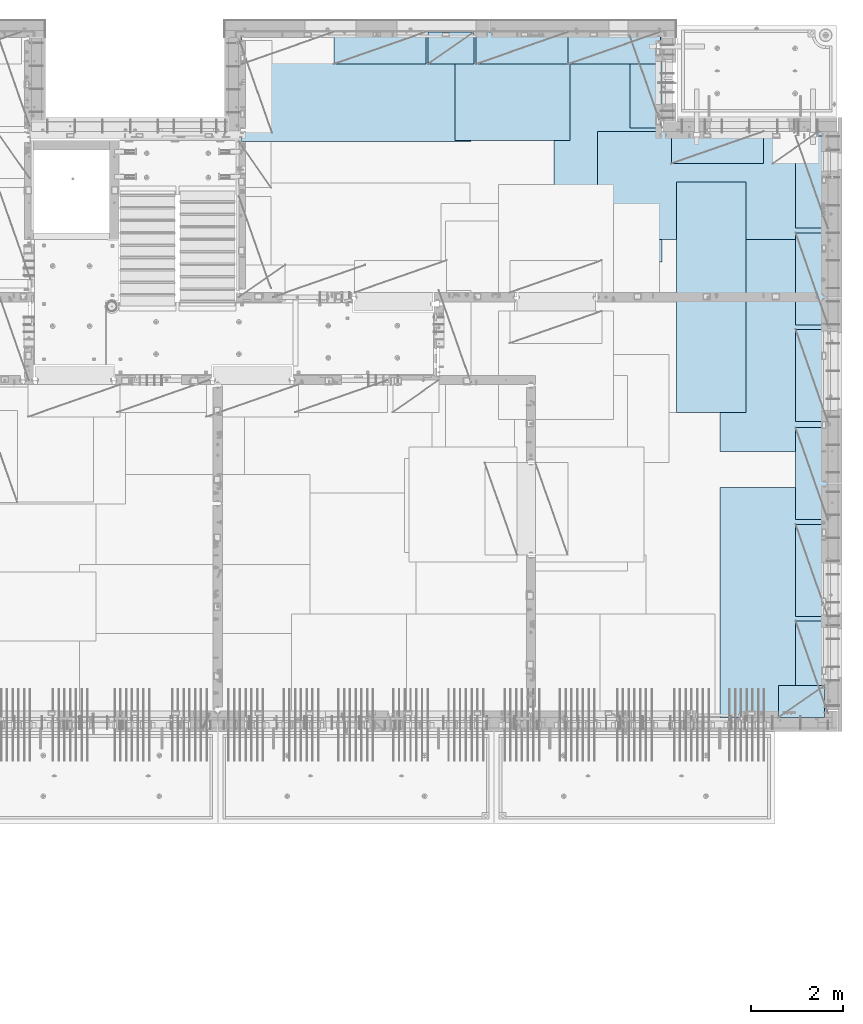
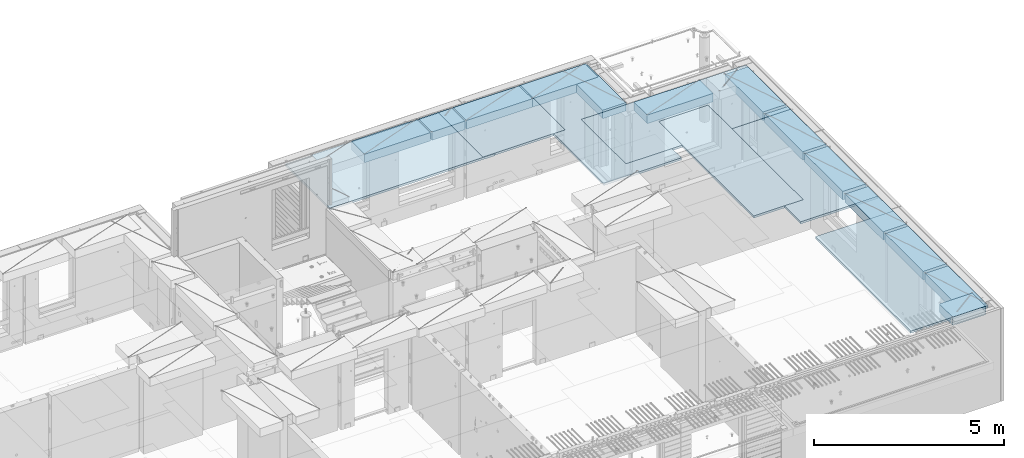
# One storey, part 210 of 349: 20 plates, 20 elements without a shape of their own.
"""IFC2X3 building model written with IfcOpenShell, lengths in millimetres."""

from ifc_helpers import new_model, si_unit, frame, origin_with_axes, place, context, subcontext, project, spatial, faceted_brep, material, type_object, element, aggregate, save


model = new_model("IFC2X3")

# Units and contexts
model_context = context("Model", 3, precision=1e-05, world=origin_with_axes())
body_context = subcontext(model_context, "Body", "Model", "MODEL_VIEW")
ifc_project = project(units=[si_unit("LENGTHUNIT", "METRE", prefix="MILLI"), si_unit("AREAUNIT", "SQUARE_METRE"), si_unit("VOLUMEUNIT", "CUBIC_METRE"), si_unit("MASSUNIT", "GRAM", prefix="KILO"), si_unit("TIMEUNIT", "SECOND"), si_unit("PLANEANGLEUNIT", "RADIAN"), si_unit("SOLIDANGLEUNIT", "STERADIAN"), si_unit("THERMODYNAMICTEMPERATUREUNIT", "DEGREE_CELSIUS"), si_unit("LUMINOUSINTENSITYUNIT", "LUMEN")], contexts=[model_context])

# Site, building, storey
site_placement = place(None, origin_with_axes())
site = spatial("IfcSite", under=ifc_project, at=site_placement, CompositionType="ELEMENT")
building_placement = place(site_placement, origin_with_axes())
building = spatial("IfcBuilding", under=site, at=building_placement, CompositionType="ELEMENT")
storey_placement = place(building_placement, origin_with_axes())
storey = spatial("IfcBuildingStorey", under=building, at=storey_placement, Name="4", CompositionType="ELEMENT", Elevation=0.0)

# Assembly, plate
assembly_1_placement = place(storey_placement, origin_with_axes())
assembly_1 = element("IfcElementAssembly", 1, at=assembly_1_placement, inside=storey, Name="Steel Assembly", AssemblyPlace="NOTDEFINED", PredefinedType="NOTDEFINED")
ifc_material = material()
plate_type_1 = type_object("IfcPlateType", PredefinedType="NOTDEFINED")
plate_1_placement = place(assembly_1_placement, frame((26960.07, 22728.45, 93695.1), z_axis=(1.0, 0.0, 0.0), x_axis=(0.0, -1.0, 0.0)))
plate_1 = element("IfcPlate", 2, at=plate_1_placement, type_object=plate_type_1, material=ifc_material, Name="1/2", context=body_context, shape_type="Brep", body=[
    faceted_brep([(0.0, -35.0, 0.0), (0.0, -35.0, 2500.0), (0.0, 35.0, 2500.0), (0.0, 35.0, 0.0), (2349.99951171875, -35.0, 2500.0), (2349.99951171875, 35.0, 2500.0), (2350.0, -35.0, 0.0), (2350.0, 35.0, 0.0)], [[[0, 1, 2, 3]], [[1, 4, 5, 2]], [[4, 6, 7, 5]], [[6, 0, 3, 7]], [[5, 7, 3, 2]], [[6, 4, 1, 0]]]),
])
aggregate(assembly_1, [plate_1])

assembly_2_placement = place(storey_placement, origin_with_axes())
assembly_2 = element("IfcElementAssembly", 3, at=assembly_2_placement, inside=storey, Name="Steel Assembly", AssemblyPlace="NOTDEFINED", PredefinedType="NOTDEFINED")
plate_2_placement = place(assembly_2_placement, frame((22309.9998779297, 22710.0009765625, 93695.1), z_axis=(1.0, 0.0, 0.0), x_axis=(0.0, -1.0, 0.0)))
plate_2 = element("IfcPlate", 4, at=plate_2_placement, type_object=plate_type_1, material=ifc_material, context=body_context, shape_type="Brep", body=[
    faceted_brep([(0.0, -35.0, 0.0), (0.0, -35.0, 5000.0), (0.0, 35.0, 5000.0), (0.0, 35.0, 0.0), (2349.99951171875, -35.0, 5000.0), (2349.99951171875, 35.0, 5000.0), (2350.0, -35.0, 0.0), (2350.0, 35.0, 0.0)], [[[0, 1, 2, 3]], [[1, 4, 5, 2]], [[4, 6, 7, 5]], [[6, 0, 3, 7]], [[5, 7, 3, 2]], [[6, 4, 1, 0]]]),
])
aggregate(assembly_2, [plate_2])

assembly_3_placement = place(storey_placement, origin_with_axes())
assembly_3 = element("IfcElementAssembly", 5, at=assembly_3_placement, inside=storey, Name="Steel Assembly", AssemblyPlace="NOTDEFINED", PredefinedType="NOTDEFINED")
plate_3_placement = place(assembly_3_placement, frame((31460.0, 22740.0, 93695.1), z_axis=(0.0, -1.0, 0.0), x_axis=(-1.0, 3.00000001838171e-08, 0.0)))
plate_3 = element("IfcPlate", 6, at=plate_3_placement, type_object=plate_type_1, material=ifc_material, context=body_context, shape_type="Brep", body=[
    faceted_brep([(0.0, -35.0, 0.0), (0.0, -35.0, 5000.0), (0.0, 35.0, 5000.0), (0.0, 35.0, 0.0), (2349.99951171875, -35.0, 5000.0), (2349.99951171875, 35.0, 5000.0), (2350.0, -35.0, 0.0), (2350.0, 35.0, 0.0)], [[[0, 1, 2, 3]], [[1, 4, 5, 2]], [[4, 6, 7, 5]], [[6, 0, 3, 7]], [[5, 7, 3, 2]], [[6, 4, 1, 0]]]),
])
aggregate(assembly_3, [plate_3])

assembly_4_placement = place(storey_placement, origin_with_axes())
assembly_4 = element("IfcElementAssembly", 7, at=assembly_4_placement, inside=storey, Name="Steel Assembly", AssemblyPlace="NOTDEFINED", PredefinedType="NOTDEFINED")
plate_4_placement = place(assembly_4_placement, frame((35060.0, 12850.0, 93695.1), z_axis=(0.0, -1.0, 0.0), x_axis=(-1.0, 3.00000001838171e-08, 0.0)))
plate_4 = element("IfcPlate", 8, at=plate_4_placement, type_object=plate_type_1, material=ifc_material, context=body_context, shape_type="Brep", body=[
    faceted_brep([(0.0, -35.0, 0.0), (0.0, -35.0, 5000.0), (0.0, 35.0, 5000.0), (0.0, 35.0, 0.0), (2349.99951171875, -35.0, 5000.0), (2349.99951171875, 35.0, 5000.0), (2350.0, -35.0, 0.0), (2350.0, 35.0, 0.0)], [[[0, 1, 2, 3]], [[1, 4, 5, 2]], [[4, 6, 7, 5]], [[6, 0, 3, 7]], [[5, 7, 3, 2]], [[6, 4, 1, 0]]]),
])
aggregate(assembly_4, [plate_4])

assembly_5_placement = place(storey_placement, origin_with_axes())
assembly_5 = element("IfcElementAssembly", 9, at=assembly_5_placement, inside=storey, Name="Steel Assembly", AssemblyPlace="NOTDEFINED", PredefinedType="NOTDEFINED")
plate_5_placement = place(assembly_5_placement, frame((35060.0, 18630.0, 93695.1), z_axis=(0.0, -1.0, 0.0), x_axis=(-1.0, 3.00000001838171e-08, 0.0)))
plate_5 = element("IfcPlate", 10, at=plate_5_placement, type_object=plate_type_1, material=ifc_material, context=body_context, shape_type="Brep", body=[
    faceted_brep([(0.0, -35.0, 0.0), (0.0, -35.0, 5000.0), (0.0, 35.0, 5000.0), (0.0, 35.0, 0.0), (2349.99951171875, -35.0, 5000.0), (2349.99951171875, 35.0, 5000.0), (2350.0, -35.0, 0.0), (2350.0, 35.0, 0.0)], [[[0, 1, 2, 3]], [[1, 4, 5, 2]], [[4, 6, 7, 5]], [[6, 0, 3, 7]], [[5, 7, 3, 2]], [[6, 4, 1, 0]]]),
])
aggregate(assembly_5, [plate_5])

assembly_6_placement = place(storey_placement, origin_with_axes())
assembly_6 = element("IfcElementAssembly", 11, at=assembly_6_placement, inside=storey, Name="Steel Assembly", AssemblyPlace="NOTDEFINED", PredefinedType="NOTDEFINED")
plate_6_placement = place(assembly_6_placement, frame((30060.0, 20580.0, 93695.1), z_axis=(1.0, 0.0, 0.0), x_axis=(0.0, -1.0, 0.0)))
plate_6 = element("IfcPlate", 12, at=plate_6_placement, type_object=plate_type_1, material=ifc_material, context=body_context, shape_type="Brep", body=[
    faceted_brep([(0.0, -35.0, 0.0), (0.0, -35.0, 5000.0), (0.0, 35.0, 5000.0), (0.0, 35.0, 0.0), (2349.99951171875, -35.0, 5000.0), (2349.99951171875, 35.0, 5000.0), (2350.0, -35.0, 0.0), (2350.0, 35.0, 0.0)], [[[0, 1, 2, 3]], [[1, 4, 5, 2]], [[4, 6, 7, 5]], [[6, 0, 3, 7]], [[5, 7, 3, 2]], [[6, 4, 1, 0]]]),
])
aggregate(assembly_6, [plate_6])

assembly_7_placement = place(storey_placement, origin_with_axes())
assembly_7 = element("IfcElementAssembly", 13, at=assembly_7_placement, inside=storey, Name="Steel Assembly", AssemblyPlace="NOTDEFINED", PredefinedType="NOTDEFINED")
plate_type_2 = type_object("IfcPlateType", PredefinedType="NOTDEFINED")
plate_7_placement = place(assembly_7_placement, frame((33275.0000122641, 19480.0, 93695.1000003815), z_axis=(0.0, -1.0, 0.0), x_axis=(-1.0, 3.00000001838171e-08, 0.0)))
plate_7 = element("IfcPlate", 14, at=plate_7_placement, type_object=plate_type_2, material=ifc_material, context=body_context, shape_type="Brep", body=[
    faceted_brep([(0.0, -35.0, 0.0), (0.0, -35.0, 5000.0), (0.0, 35.0, 5000.0), (0.0, 35.0, 0.0), (1499.99951171875, -35.0, 5000.0), (1499.99951171875, 35.0, 5000.0), (1500.0, -35.0, 0.0), (1500.0, 35.0, 0.0)], [[[0, 1, 2, 3]], [[1, 4, 5, 2]], [[4, 6, 7, 5]], [[6, 0, 3, 7]], [[5, 7, 3, 2]], [[6, 4, 1, 0]]]),
])
aggregate(assembly_7, [plate_7])

assembly_8_placement = place(storey_placement, origin_with_axes())
assembly_8 = element("IfcElementAssembly", 15, at=assembly_8_placement, inside=storey, Name="Steel Assembly", AssemblyPlace="NOTDEFINED", PredefinedType="NOTDEFINED")
plate_type_3 = type_object("IfcPlateType", PredefinedType="NOTDEFINED")
plate_8_placement = place(assembly_8_placement, frame((31420.0, 22740.0001220703, 93595.3), z_axis=(0.0, -1.0, 0.0), x_axis=(-1.0, 3.00000001838171e-08, 0.0)))
plate_8 = element("IfcPlate", 16, at=plate_8_placement, type_object=plate_type_3, material=ifc_material, Name="RE1", context=body_context, shape_type="Brep", body=[
    faceted_brep([(1.81898940354586e-12, -135.0, 1.81898940354586e-12), (0.0, -135.0, 699.999999999996), (0.0, 135.0, 699.999999999996), (1.81898940354586e-12, 135.0, 1.81898940354586e-12), (1999.99951171875, -135.0, 699.999999999993), (1999.99951171875, 135.0, 699.999999999993), (2000.0, -135.0, -3.63797880709171e-12), (2000.0, 135.0, -3.63797880709171e-12)], [[[0, 1, 2, 3]], [[1, 4, 5, 2]], [[4, 6, 7, 5]], [[6, 0, 3, 7]], [[5, 7, 3, 2]], [[6, 4, 1, 0]]]),
])
aggregate(assembly_8, [plate_8])

assembly_9_placement = place(storey_placement, origin_with_axes())
assembly_9 = element("IfcElementAssembly", 17, at=assembly_9_placement, inside=storey, Name="Steel Assembly", AssemblyPlace="NOTDEFINED", PredefinedType="NOTDEFINED")
plate_9_placement = place(assembly_9_placement, frame((33985.0, 7849.99999992931, 93595.3), z_axis=(0.0, 1.0, 0.0), x_axis=(1.0, 0.0, 0.0)))
plate_9 = element("IfcPlate", 18, at=plate_9_placement, type_object=plate_type_3, material=ifc_material, Name="RE1_1/2", context=body_context, shape_type="Brep", body=[
    faceted_brep([(1.81898940354586e-12, -135.0, 1.81898940354586e-12), (0.0, -135.0, 699.999999999996), (0.0, 135.0, 699.999999999996), (1.81898940354586e-12, 135.0, 1.81898940354586e-12), (999.99951171875, -135.0, 700.0), (999.99951171875, 135.0, 700.0), (1000.0, -135.0, 0.0), (1000.0, 135.0, 0.0)], [[[0, 1, 2, 3]], [[1, 4, 5, 2]], [[4, 6, 7, 5]], [[6, 0, 3, 7]], [[5, 7, 3, 2]], [[6, 4, 1, 0]]]),
])
aggregate(assembly_9, [plate_9])

assembly_10_placement = place(storey_placement, origin_with_axes())
assembly_10 = element("IfcElementAssembly", 19, at=assembly_10_placement, inside=storey, Name="Steel Assembly", AssemblyPlace="NOTDEFINED", PredefinedType="NOTDEFINED")
plate_10_placement = place(assembly_10_placement, frame((35060.0001220703, 14280.0, 93595.3), z_axis=(-1.0, 3.00000001838171e-08, 0.0), x_axis=(0.0, 1.0, 0.0)))
plate_10 = element("IfcPlate", 20, at=plate_10_placement, type_object=plate_type_3, material=ifc_material, Name="RE1", context=body_context, shape_type="Brep", body=[
    faceted_brep([(1.81898940354586e-12, -135.0, 1.81898940354586e-12), (0.0, -135.0, 699.999999999996), (0.0, 135.0, 699.999999999996), (1.81898940354586e-12, 135.0, 1.81898940354586e-12), (1999.99951171875, -135.0, 699.999999999993), (1999.99951171875, 135.0, 699.999999999993), (2000.0, -135.0, -3.63797880709171e-12), (2000.0, 135.0, -3.63797880709171e-12)], [[[0, 1, 2, 3]], [[1, 4, 5, 2]], [[4, 6, 7, 5]], [[6, 0, 3, 7]], [[5, 7, 3, 2]], [[6, 4, 1, 0]]]),
])
aggregate(assembly_10, [plate_10])

assembly_11_placement = place(storey_placement, origin_with_axes())
assembly_11 = element("IfcElementAssembly", 21, at=assembly_11_placement, inside=storey, Name="Steel Assembly", AssemblyPlace="NOTDEFINED", PredefinedType="NOTDEFINED")
plate_11_placement = place(assembly_11_placement, frame((35060.0001220703, 16380.0, 93595.3), z_axis=(-1.0, 3.00000001838171e-08, 0.0), x_axis=(0.0, 1.0, 0.0)))
plate_11 = element("IfcPlate", 22, at=plate_11_placement, type_object=plate_type_3, material=ifc_material, Name="RE1", context=body_context, shape_type="Brep", body=[
    faceted_brep([(1.81898940354586e-12, -135.0, 1.81898940354586e-12), (0.0, -135.0, 699.999999999996), (0.0, 135.0, 699.999999999996), (1.81898940354586e-12, 135.0, 1.81898940354586e-12), (1999.99951171875, -135.0, 699.999999999993), (1999.99951171875, 135.0, 699.999999999993), (2000.0, -135.0, -3.63797880709171e-12), (2000.0, 135.0, -3.63797880709171e-12)], [[[0, 1, 2, 3]], [[1, 4, 5, 2]], [[4, 6, 7, 5]], [[6, 0, 3, 7]], [[5, 7, 3, 2]], [[6, 4, 1, 0]]]),
])
aggregate(assembly_11, [plate_11])

assembly_12_placement = place(storey_placement, origin_with_axes())
assembly_12 = element("IfcElementAssembly", 23, at=assembly_12_placement, inside=storey, Name="Steel Assembly", AssemblyPlace="NOTDEFINED", PredefinedType="NOTDEFINED")
plate_12_placement = place(assembly_12_placement, frame((35060.0001220703, 18480.0, 93595.3), z_axis=(-1.0, 3.00000001838171e-08, 0.0), x_axis=(0.0, 1.0, 0.0)))
plate_12 = element("IfcPlate", 24, at=plate_12_placement, type_object=plate_type_3, material=ifc_material, Name="RE1", context=body_context, shape_type="Brep", body=[
    faceted_brep([(1.81898940354586e-12, -135.0, 1.81898940354586e-12), (0.0, -135.0, 699.999999999996), (0.0, 135.0, 699.999999999996), (1.81898940354586e-12, 135.0, 1.81898940354586e-12), (1999.99951171875, -135.0, 699.999999999993), (1999.99951171875, 135.0, 699.999999999993), (2000.0, -135.0, -3.63797880709171e-12), (2000.0, 135.0, -3.63797880709171e-12)], [[[0, 1, 2, 3]], [[1, 4, 5, 2]], [[4, 6, 7, 5]], [[6, 0, 3, 7]], [[5, 7, 3, 2]], [[6, 4, 1, 0]]]),
])
aggregate(assembly_12, [plate_12])

assembly_13_placement = place(storey_placement, origin_with_axes())
assembly_13 = element("IfcElementAssembly", 25, at=assembly_13_placement, inside=storey, Name="Steel Assembly", AssemblyPlace="NOTDEFINED", PredefinedType="NOTDEFINED")
plate_13_placement = place(assembly_13_placement, frame((35060.0001220703, 12150.0, 93595.3), z_axis=(-1.0, 3.00000001838171e-08, 0.0), x_axis=(0.0, 1.0, 0.0)))
plate_13 = element("IfcPlate", 26, at=plate_13_placement, type_object=plate_type_3, material=ifc_material, Name="RE1", context=body_context, shape_type="Brep", body=[
    faceted_brep([(1.81898940354586e-12, -135.0, 1.81898940354586e-12), (0.0, -135.0, 699.999999999996), (0.0, 135.0, 699.999999999996), (1.81898940354586e-12, 135.0, 1.81898940354586e-12), (1999.99951171875, -135.0, 699.999999999993), (1999.99951171875, 135.0, 699.999999999993), (2000.0, -135.0, -3.63797880709171e-12), (2000.0, 135.0, -3.63797880709171e-12)], [[[0, 1, 2, 3]], [[1, 4, 5, 2]], [[4, 6, 7, 5]], [[6, 0, 3, 7]], [[5, 7, 3, 2]], [[6, 4, 1, 0]]]),
])
aggregate(assembly_13, [plate_13])

assembly_14_placement = place(storey_placement, origin_with_axes())
assembly_14 = element("IfcElementAssembly", 27, at=assembly_14_placement, inside=storey, Name="Steel Assembly", AssemblyPlace="NOTDEFINED", PredefinedType="NOTDEFINED")
plate_14_placement = place(assembly_14_placement, frame((35060.0001220703, 10050.0, 93595.3), z_axis=(-1.0, 3.00000001838171e-08, 0.0), x_axis=(0.0, 1.0, 0.0)))
plate_14 = element("IfcPlate", 28, at=plate_14_placement, type_object=plate_type_3, material=ifc_material, Name="RE1", context=body_context, shape_type="Brep", body=[
    faceted_brep([(1.81898940354586e-12, -135.0, 1.81898940354586e-12), (0.0, -135.0, 699.999999999996), (0.0, 135.0, 699.999999999996), (1.81898940354586e-12, 135.0, 1.81898940354586e-12), (1999.99951171875, -135.0, 699.999999999993), (1999.99951171875, 135.0, 699.999999999993), (2000.0, -135.0, -3.63797880709171e-12), (2000.0, 135.0, -3.63797880709171e-12)], [[[0, 1, 2, 3]], [[1, 4, 5, 2]], [[4, 6, 7, 5]], [[6, 0, 3, 7]], [[5, 7, 3, 2]], [[6, 4, 1, 0]]]),
])
aggregate(assembly_14, [plate_14])

assembly_15_placement = place(storey_placement, origin_with_axes())
assembly_15 = element("IfcElementAssembly", 29, at=assembly_15_placement, inside=storey, Name="Steel Assembly", AssemblyPlace="NOTDEFINED", PredefinedType="NOTDEFINED")
plate_15_placement = place(assembly_15_placement, frame((35060.0001220703, 7950.0, 93595.3), z_axis=(-1.0, 3.00000001838171e-08, 0.0), x_axis=(0.0, 1.0, 0.0)))
plate_15 = element("IfcPlate", 30, at=plate_15_placement, type_object=plate_type_3, material=ifc_material, Name="RE1", context=body_context, shape_type="Brep", body=[
    faceted_brep([(1.81898940354586e-12, -135.0, 1.81898940354586e-12), (0.0, -135.0, 699.999999999996), (0.0, 135.0, 699.999999999996), (1.81898940354586e-12, 135.0, 1.81898940354586e-12), (1999.99951171875, -135.0, 699.999999999993), (1999.99951171875, 135.0, 699.999999999993), (2000.0, -135.0, -3.63797880709171e-12), (2000.0, 135.0, -3.63797880709171e-12)], [[[0, 1, 2, 3]], [[1, 4, 5, 2]], [[4, 6, 7, 5]], [[6, 0, 3, 7]], [[5, 7, 3, 2]], [[6, 4, 1, 0]]]),
])
aggregate(assembly_15, [plate_15])

assembly_16_placement = place(storey_placement, origin_with_axes())
assembly_16 = element("IfcElementAssembly", 31, at=assembly_16_placement, inside=storey, Name="Steel Assembly", AssemblyPlace="NOTDEFINED", PredefinedType="NOTDEFINED")
plate_16_placement = place(assembly_16_placement, frame((33660.0, 20580.0001220703, 93595.3), z_axis=(0.0, -1.0, 0.0), x_axis=(-1.0, 3.00000001838171e-08, 0.0)))
plate_16 = element("IfcPlate", 32, at=plate_16_placement, type_object=plate_type_3, material=ifc_material, Name="RE1", context=body_context, shape_type="Brep", body=[
    faceted_brep([(1.81898940354586e-12, -135.0, 1.81898940354586e-12), (0.0, -135.0, 699.999999999996), (0.0, 135.0, 699.999999999996), (1.81898940354586e-12, 135.0, 1.81898940354586e-12), (1999.99951171875, -135.0, 699.999999999993), (1999.99951171875, 135.0, 699.999999999993), (2000.0, -135.0, -3.63797880709171e-12), (2000.0, 135.0, -3.63797880709171e-12)], [[[0, 1, 2, 3]], [[1, 4, 5, 2]], [[4, 6, 7, 5]], [[6, 0, 3, 7]], [[5, 7, 3, 2]], [[6, 4, 1, 0]]]),
])
aggregate(assembly_16, [plate_16])

assembly_17_placement = place(storey_placement, origin_with_axes())
assembly_17 = element("IfcElementAssembly", 33, at=assembly_17_placement, inside=storey, Name="Steel Assembly", AssemblyPlace="NOTDEFINED", PredefinedType="NOTDEFINED")
plate_17_placement = place(assembly_17_placement, frame((31460.0001220703, 20660.0, 93595.3), z_axis=(-1.0, 3.00000001838171e-08, 0.0), x_axis=(0.0, 1.0, 0.0)))
plate_17 = element("IfcPlate", 34, at=plate_17_placement, type_object=plate_type_3, material=ifc_material, Name="RE1", context=body_context, shape_type="Brep", body=[
    faceted_brep([(1.81898940354586e-12, -135.0, 1.81898940354586e-12), (0.0, -135.0, 699.999999999996), (0.0, 135.0, 699.999999999996), (1.81898940354586e-12, 135.0, 1.81898940354586e-12), (1999.99951171875, -135.0, 699.999999999993), (1999.99951171875, 135.0, 699.999999999993), (2000.0, -135.0, -3.63797880709171e-12), (2000.0, 135.0, -3.63797880709171e-12)], [[[0, 1, 2, 3]], [[1, 4, 5, 2]], [[4, 6, 7, 5]], [[6, 0, 3, 7]], [[5, 7, 3, 2]], [[6, 4, 1, 0]]]),
])
aggregate(assembly_17, [plate_17])

assembly_18_placement = place(storey_placement, origin_with_axes())
assembly_18 = element("IfcElementAssembly", 35, at=assembly_18_placement, inside=storey, Name="Steel Assembly", AssemblyPlace="NOTDEFINED", PredefinedType="NOTDEFINED")
plate_18_placement = place(assembly_18_placement, frame((26330.0, 22740.0001220703, 93595.3), z_axis=(0.0, -1.0, 0.0), x_axis=(-1.0, 3.00000001838171e-08, 0.0)))
plate_18 = element("IfcPlate", 36, at=plate_18_placement, type_object=plate_type_3, material=ifc_material, Name="RE1", context=body_context, shape_type="Brep", body=[
    faceted_brep([(1.81898940354586e-12, -135.0, 1.81898940354586e-12), (0.0, -135.0, 699.999999999996), (0.0, 135.0, 699.999999999996), (1.81898940354586e-12, 135.0, 1.81898940354586e-12), (1999.99951171875, -135.0, 699.999999999993), (1999.99951171875, 135.0, 699.999999999993), (2000.0, -135.0, -3.63797880709171e-12), (2000.0, 135.0, -3.63797880709171e-12)], [[[0, 1, 2, 3]], [[1, 4, 5, 2]], [[4, 6, 7, 5]], [[6, 0, 3, 7]], [[5, 7, 3, 2]], [[6, 4, 1, 0]]]),
])
aggregate(assembly_18, [plate_18])

assembly_19_placement = place(storey_placement, origin_with_axes())
assembly_19 = element("IfcElementAssembly", 37, at=assembly_19_placement, inside=storey, Name="Steel Assembly", AssemblyPlace="NOTDEFINED", PredefinedType="NOTDEFINED")
plate_19_placement = place(assembly_19_placement, frame((29420.0, 22740.0001220703, 93595.3), z_axis=(0.0, -1.0, 0.0), x_axis=(-1.0, 3.00000001838171e-08, 0.0)))
plate_19 = element("IfcPlate", 38, at=plate_19_placement, type_object=plate_type_3, material=ifc_material, Name="RE1", context=body_context, shape_type="Brep", body=[
    faceted_brep([(1.81898940354586e-12, -135.0, 1.81898940354586e-12), (0.0, -135.0, 699.999999999996), (0.0, 135.0, 699.999999999996), (1.81898940354586e-12, 135.0, 1.81898940354586e-12), (1999.99951171875, -135.0, 699.999999999993), (1999.99951171875, 135.0, 699.999999999993), (2000.0, -135.0, -3.63797880709171e-12), (2000.0, 135.0, -3.63797880709171e-12)], [[[0, 1, 2, 3]], [[1, 4, 5, 2]], [[4, 6, 7, 5]], [[6, 0, 3, 7]], [[5, 7, 3, 2]], [[6, 4, 1, 0]]]),
])
aggregate(assembly_19, [plate_19])

assembly_20_placement = place(storey_placement, origin_with_axes())
assembly_20 = element("IfcElementAssembly", 39, at=assembly_20_placement, inside=storey, Name="Steel Assembly", AssemblyPlace="NOTDEFINED", PredefinedType="NOTDEFINED")
plate_20_placement = place(assembly_20_placement, frame((27375.0, 22740.0000000707, 93595.3), z_axis=(0.0, -1.0, 0.0), x_axis=(-1.0, 3.00000001838171e-08, 0.0)))
plate_20 = element("IfcPlate", 40, at=plate_20_placement, type_object=plate_type_3, material=ifc_material, Name="RE1_1/2", context=body_context, shape_type="Brep", body=[
    faceted_brep([(1.81898940354586e-12, -135.0, 1.81898940354586e-12), (0.0, -135.0, 699.999999999996), (0.0, 135.0, 699.999999999996), (1.81898940354586e-12, 135.0, 1.81898940354586e-12), (999.99951171875, -135.0, 700.0), (999.99951171875, 135.0, 700.0), (1000.0, -135.0, 0.0), (1000.0, 135.0, 0.0)], [[[0, 1, 2, 3]], [[1, 4, 5, 2]], [[4, 6, 7, 5]], [[6, 0, 3, 7]], [[5, 7, 3, 2]], [[6, 4, 1, 0]]]),
])
aggregate(assembly_20, [plate_20])

save(model, "model.ifc")
